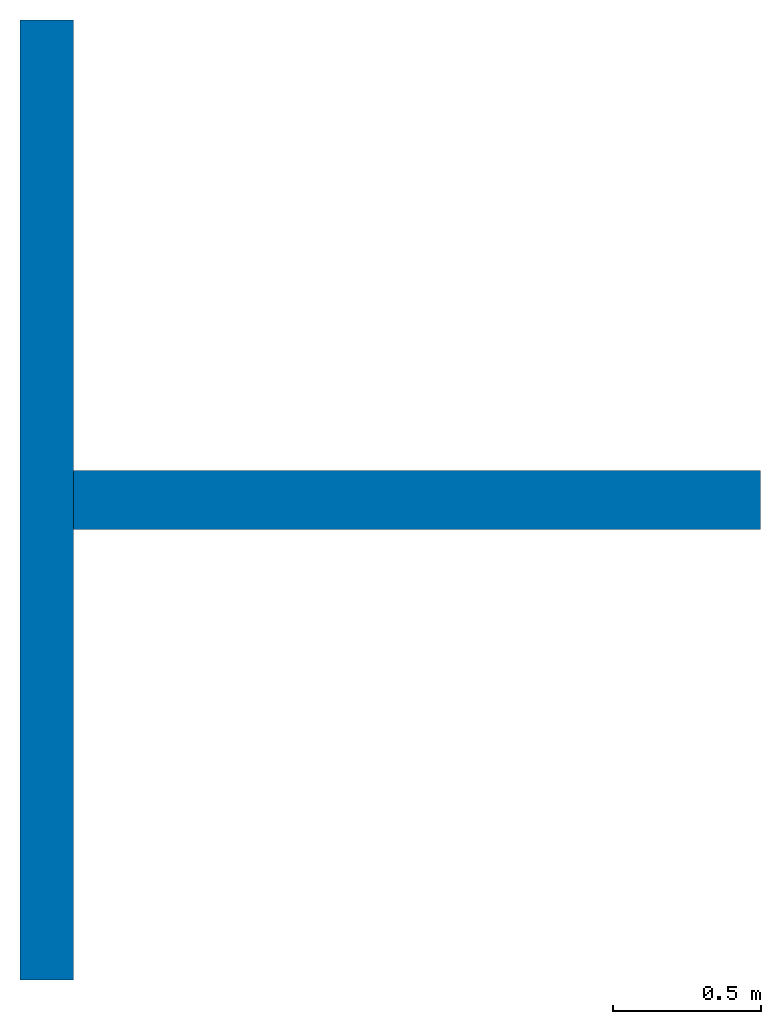
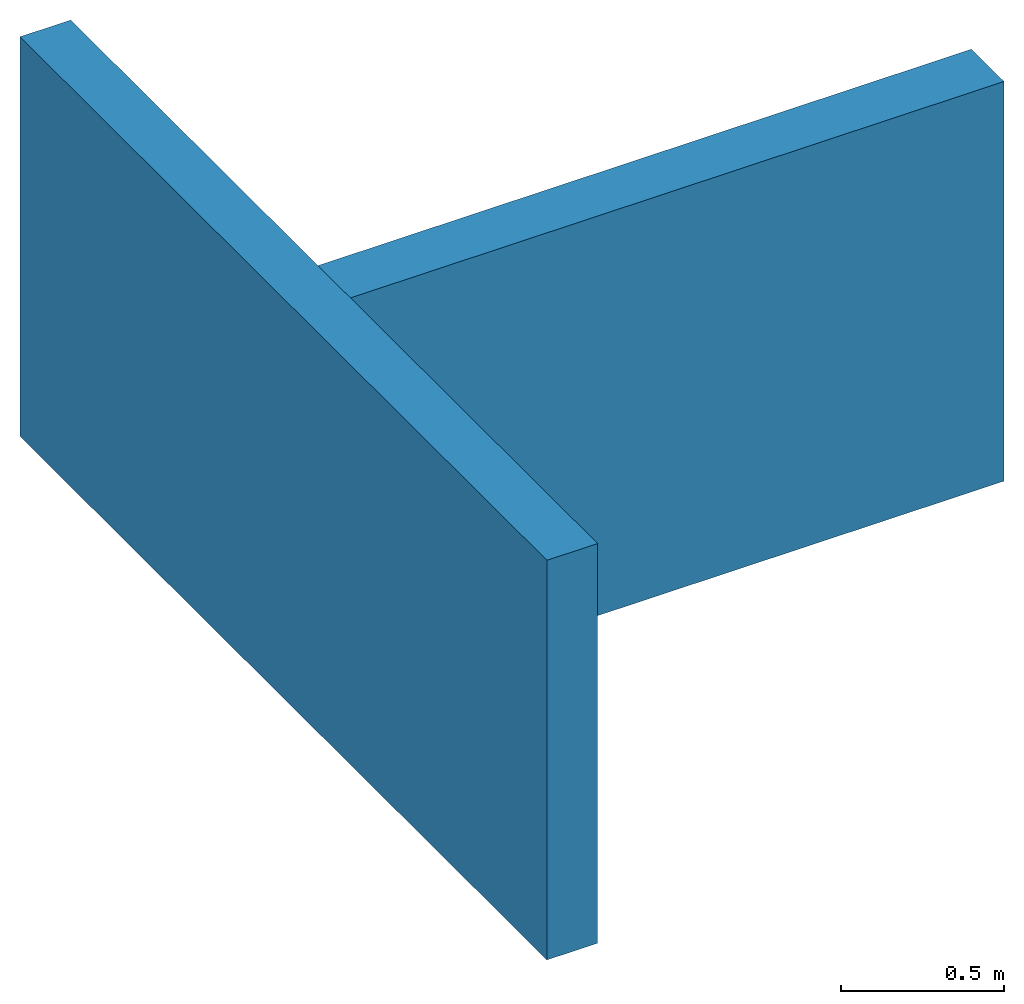
# One storey: 2 walls.
"""IFC4 building model written with IfcOpenShell, lengths in metres."""

from ifc_helpers import new_model, entity, si_unit, converted_unit, derived_unit, direction, frame, origin_with_axes, place, context, subcontext, project, spatial, polygons, material, type_object, element, save


model = new_model("IFC4")

# Units and contexts
model_context = context("Model", 3, precision=1e-05, world=origin_with_axes(), true_north=direction((0.0, 1.0)))
body_context = subcontext(model_context, "Body", "Model", "MODEL_VIEW")
ifc_project = project(units=[si_unit("LENGTHUNIT", "METRE"), si_unit("AREAUNIT", "SQUARE_METRE"), si_unit("VOLUMEUNIT", "CUBIC_METRE"), converted_unit("PLANEANGLEUNIT", "DEGREE", entity("IfcPlaneAngleMeasure", 0.0174532925199433), si_unit("PLANEANGLEUNIT", "RADIAN"), dimensions=[0, 0, 0, 0, 0, 0, 0]), converted_unit("TIMEUNIT", "Year", entity("IfcTimeMeasure", 31557600.0), si_unit("TIMEUNIT", "SECOND"), dimensions=[0, 0, 1, 0, 0, 0, 0]), si_unit("MASSUNIT", "GRAM", prefix="KILO"), si_unit("THERMODYNAMICTEMPERATUREUNIT", "DEGREE_CELSIUS"), si_unit("LUMINOUSINTENSITYUNIT", "LUMEN"), si_unit("ENERGYUNIT", "JOULE", prefix="MEGA"), derived_unit("THERMALCONDUCTANCEUNIT", [(si_unit("POWERUNIT", "WATT"), 1), (si_unit("LENGTHUNIT", "METRE"), -1), (si_unit("THERMODYNAMICTEMPERATUREUNIT", "KELVIN"), -1)]), derived_unit("SPECIFICHEATCAPACITYUNIT", [(si_unit("ENERGYUNIT", "JOULE"), 1), (si_unit("MASSUNIT", "GRAM", prefix="KILO"), -1), (si_unit("THERMODYNAMICTEMPERATUREUNIT", "KELVIN"), -1)]), derived_unit("MASSDENSITYUNIT", [(si_unit("MASSUNIT", "GRAM", prefix="KILO"), 1), (si_unit("VOLUMEUNIT", "CUBIC_METRE"), -1)])], contexts=[model_context])

# Site, building, storey
site_placement = place(None, origin_with_axes())
site = spatial("IfcSite", under=ifc_project, at=site_placement, CompositionType="ELEMENT")
building_placement = place(None, origin_with_axes())
building = spatial("IfcBuilding", under=site, at=building_placement, CompositionType="ELEMENT")
storey_placement = place(None, frame((0.0, 0.0, 13.5), z_axis=(0.0, 0.0, 1.0), x_axis=(1.0, 0.0, 0.0)))
storey = spatial("IfcBuildingStorey", under=building, at=storey_placement, Name="Dach", CompositionType="ELEMENT", Elevation=13.5)

# Walls
ifc_material = material(Name="Stahlbeton")
wall_type_1 = type_object("IfcWallType", Name="Stahlbeton 180", PredefinedType="NOTDEFINED")
wall_1_placement = place(None, frame((29.138, 6.93499994546755, 13.5), z_axis=(0.0, 0.0, 1.0), x_axis=(0.0, 1.0, 0.0)))
element("IfcWall", 1, at=wall_1_placement, inside=storey, type_object=wall_type_1, material=ifc_material, Name="Wand-001", PredefinedType="NOTDEFINED", context=body_context, shape_type="Tessellation", body=[
    polygons([(0.3, 0.18, 0.0), (3.54, 0.18, 0.0), (3.54, 0.0, 0.0), (0.3, 0.0, 0.0), (0.3, 0.18, 1.5), (3.54, 0.18, 1.5), (3.54, 0.0, 1.5), (0.3, 0.0, 1.5)], [[[1, 2, 3, 4]], [[5, 6, 2, 1]], [[7, 3, 2, 6]], [[4, 3, 7, 8]], [[8, 5, 1, 4]], [[8, 7, 6, 5]]], closed=True),
])
wall_type_2 = type_object("IfcWallType", Name="Stahlbeton 200", PredefinedType="NOTDEFINED")
wall_2_placement = place(None, frame((29.138, 8.85499994546755, 13.5), z_axis=(0.0, 0.0, 1.0), x_axis=(1.0, 0.0, 0.0)))
element("IfcWall", 2, at=wall_2_placement, inside=storey, type_object=wall_type_2, material=ifc_material, Name="Wand-001", PredefinedType="NOTDEFINED", context=body_context, shape_type="Tessellation", body=[
    polygons([(0.0, 0.0999999999999996, 0.0), (2.32, 0.0999999999999996, 0.0), (2.32, -0.0999999999999996, 0.0), (0.0, -0.0999999999999996, 0.0), (0.0, 0.0999999999999996, 1.5), (2.32, 0.0999999999999996, 1.5), (2.32, -0.0999999999999996, 1.5), (0.0, -0.0999999999999996, 1.5)], [[[1, 2, 3, 4]], [[5, 6, 2, 1]], [[7, 3, 2, 6]], [[4, 3, 7, 8]], [[8, 5, 1, 4]], [[8, 7, 6, 5]]], closed=True),
])

save(model, "model.ifc")
